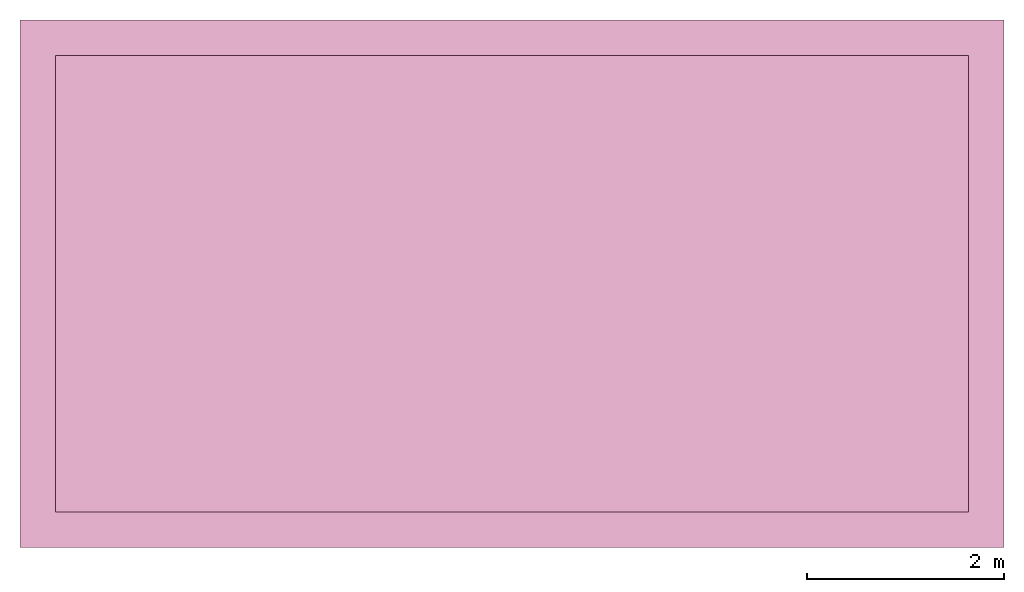
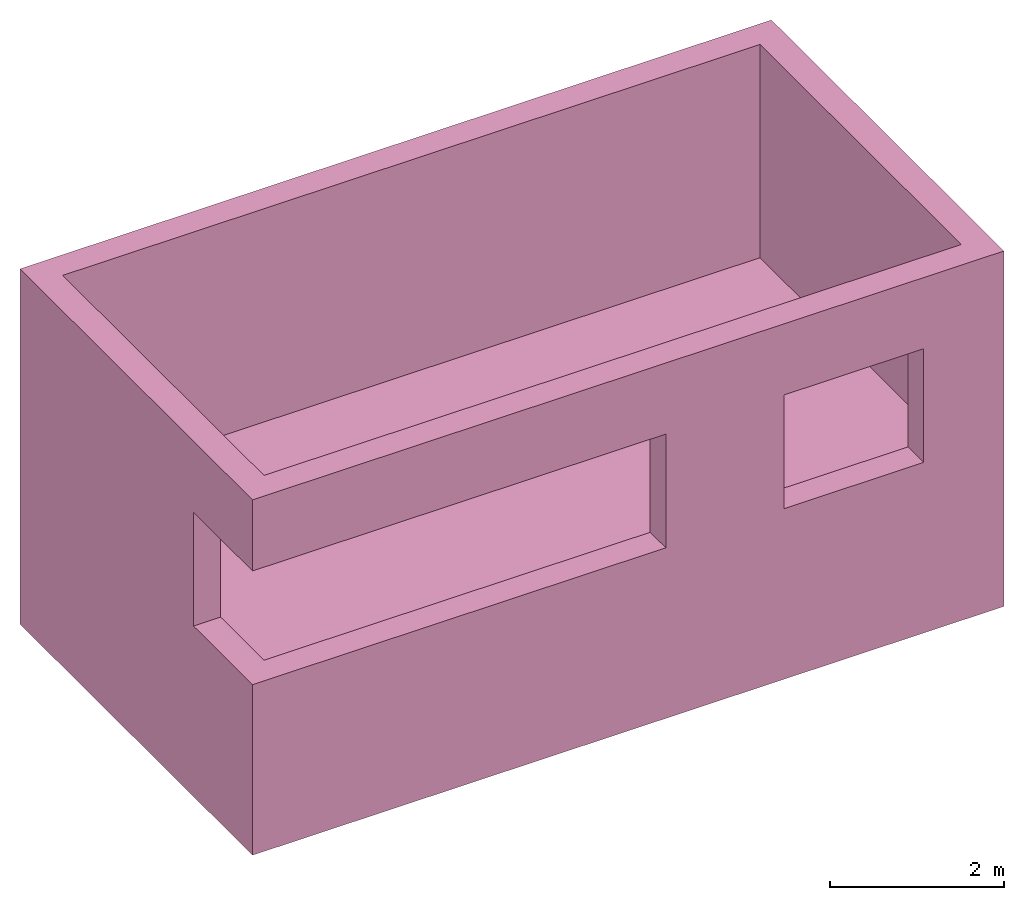
# Not in any storey: 1 furniture element.
"""IFC4 model written with IfcOpenShell, lengths in millimetres."""

from ifc_helpers import new_model, entity, si_unit, converted_unit, origin_with_axes, origin_2d_with_axis, context, project, faceted_brep, element, save


model = new_model("IFC4")

# Units and contexts
model_context_1 = context("Model", 3, precision=1e-05, world=origin_with_axes())
plan_context = context("Plan", 2, precision=1e-05, world=origin_2d_with_axis())
model_context_2 = context("Model", 3, precision=1e-05, world=origin_with_axes())
ifc_project = project(units=[si_unit("VOLUMEUNIT", "CUBIC_METRE"), si_unit("LENGTHUNIT", "METRE", prefix="MILLI"), converted_unit("PLANEANGLEUNIT", "degree", entity("IfcReal", 0.0174532925199433), si_unit("PLANEANGLEUNIT", "RADIAN"), dimensions=[0, 0, 0, 0, 0, 0, 0]), si_unit("AREAUNIT", "SQUARE_METRE")], contexts=[model_context_1, plan_context, model_context_2])

# Furniture
element("IfcFurniture", 1, context=model_context_2, shape_type="Brep", body=[
    faceted_brep([(-5000.0, -180.0, -2000.0), (-5000.0, -180.0, 400.0), (-5000.0, 1180.0, 400.0), (-5000.0, 1180.0, 2000.0), (-5000.0, -180.0, 2000.0), (-5000.0, -180.0, 3000.0), (-5000.0, 5180.0, 3000.0), (-5000.0, 5180.0, -2000.0), (5000.0, -180.0, -2000.0), (5000.0, -180.0, 3000.0), (-5000.0, -180.0, 3000.0), (-5000.0, -180.0, 2000.0), (500.0, -180.0, 2000.0), (500.0, -180.0, 400.0), (-5000.0, -180.0, 400.0), (-5000.0, -180.0, -2000.0), (2070.0, -180.0, 2000.0), (3930.0, -180.0, 2000.0), (3930.0, -180.0, 400.0), (2070.0, -180.0, 400.0), (-4640.0, 1180.0, 400.0), (-5000.0, 1180.0, 400.0), (-5000.0, -180.0, 400.0), (500.0, -180.0, 400.0), (500.0, 180.0, 400.0), (-4640.0, 180.0, 400.0), (-5000.0, 1180.0, 400.0), (-4640.0, 1180.0, 400.0), (-4640.0, 1180.0, 2000.0), (-5000.0, 1180.0, 2000.0), (-5000.0, 1180.0, 2000.0), (-4640.0, 1180.0, 2000.0), (-4640.0, 180.0, 2000.0), (500.0, 180.0, 2000.0), (500.0, -180.0, 2000.0), (-5000.0, -180.0, 2000.0), (-5000.0, 5180.0, 3000.0), (-5000.0, -180.0, 3000.0), (5000.0, -180.0, 3000.0), (5000.0, 5180.0, 3000.0), (-4640.0, 180.0, 3000.0), (-4640.0, 4820.0, 3000.0), (4640.0, 4820.0, 3000.0), (4640.0, 180.0, 3000.0), (5000.0, 5180.0, -2000.0), (-5000.0, 5180.0, -2000.0), (-5000.0, 5180.0, 3000.0), (5000.0, 5180.0, 3000.0), (-5000.0, -180.0, -2000.0), (-5000.0, 5180.0, -2000.0), (5000.0, 5180.0, -2000.0), (5000.0, -180.0, -2000.0), (5000.0, -180.0, 3000.0), (5000.0, -180.0, -2000.0), (5000.0, 5180.0, -2000.0), (5000.0, 5180.0, 3000.0), (500.0, -180.0, 2000.0), (500.0, 180.0, 2000.0), (500.0, 180.0, 400.0), (500.0, -180.0, 400.0), (2070.0, -180.0, 2000.0), (2070.0, 180.0, 2000.0), (3930.0, 180.0, 2000.0), (3930.0, -180.0, 2000.0), (3930.0, -180.0, 400.0), (3930.0, -180.0, 2000.0), (3930.0, 180.0, 2000.0), (3930.0, 180.0, 400.0), (2070.0, 180.0, 400.0), (2070.0, -180.0, 400.0), (3930.0, -180.0, 400.0), (3930.0, 180.0, 400.0), (2070.0, -180.0, 2000.0), (2070.0, -180.0, 400.0), (2070.0, 180.0, 400.0), (2070.0, 180.0, 2000.0), (-4640.0, 180.0, 400.0), (-4640.0, 180.0, 0.0), (-4640.0, 4820.0, 0.0), (-4640.0, 4820.0, 3000.0), (-4640.0, 180.0, 3000.0), (-4640.0, 180.0, 2000.0), (-4640.0, 1180.0, 2000.0), (-4640.0, 1180.0, 400.0), (4640.0, 180.0, 3000.0), (4640.0, 180.0, 0.0), (-4640.0, 180.0, 0.0), (-4640.0, 180.0, 400.0), (500.0, 180.0, 400.0), (500.0, 180.0, 2000.0), (-4640.0, 180.0, 2000.0), (-4640.0, 180.0, 3000.0), (3930.0, 180.0, 2000.0), (2070.0, 180.0, 2000.0), (2070.0, 180.0, 400.0), (3930.0, 180.0, 400.0), (4640.0, 180.0, 0.0), (4640.0, 180.0, 3000.0), (4640.0, 4820.0, 3000.0), (4640.0, 4820.0, 0.0), (-4640.0, 4820.0, 0.0), (4640.0, 4820.0, 0.0), (4640.0, 4820.0, 3000.0), (-4640.0, 4820.0, 3000.0), (-4640.0, 4820.0, 0.0), (-4640.0, 180.0, 0.0), (4640.0, 180.0, 0.0), (4640.0, 4820.0, 0.0)], [[[0, 1, 2, 3, 4, 5, 6, 7]], [[8, 9, 10, 11, 12, 13, 14, 15], [16, 17, 18, 19]], [[20, 21, 22, 23, 24, 25]], [[26, 27, 28, 29]], [[30, 31, 32, 33, 34, 35]], [[36, 37, 38, 39], [40, 41, 42, 43]], [[44, 45, 46, 47]], [[48, 49, 50, 51]], [[52, 53, 54, 55]], [[56, 57, 58, 59]], [[60, 61, 62, 63]], [[64, 65, 66, 67]], [[68, 69, 70, 71]], [[72, 73, 74, 75]], [[76, 77, 78, 79, 80, 81, 82, 83]], [[84, 85, 86, 87, 88, 89, 90, 91], [92, 93, 94, 95]], [[96, 97, 98, 99]], [[100, 101, 102, 103]], [[104, 105, 106, 107]]], outer=[[False], [False, False], [False], [False], [False], [False, False], [False], [False], [False], [False], [False], [False], [False], [False], [False], [False, False], [False], [False], [False]]),
])

save(model, "model.ifc")
